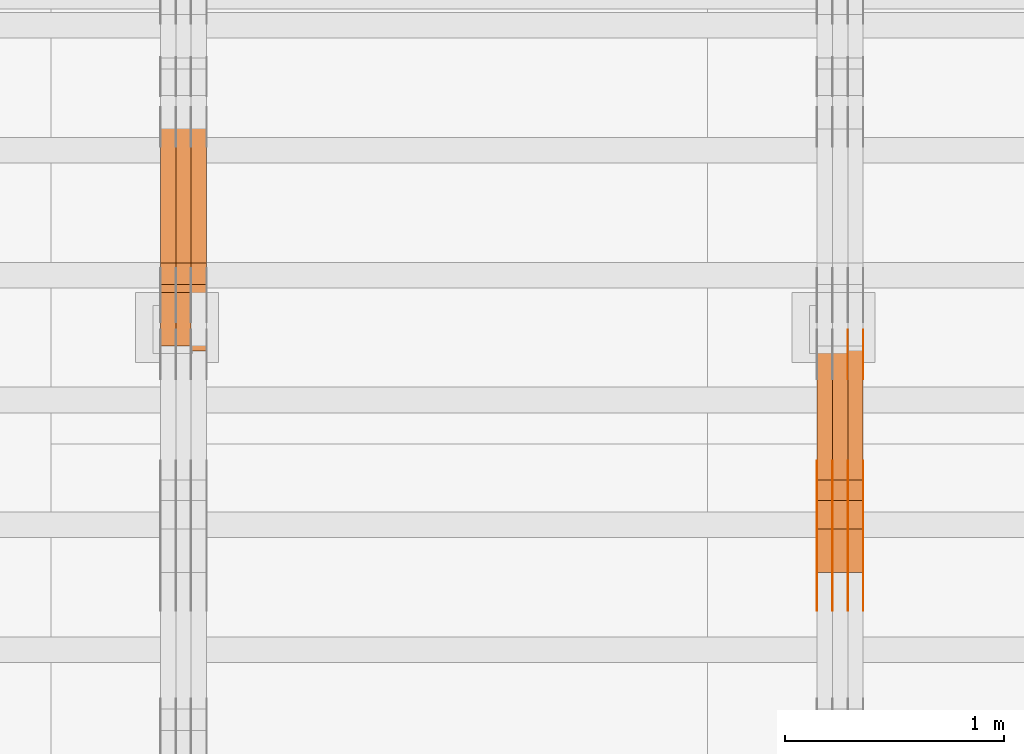
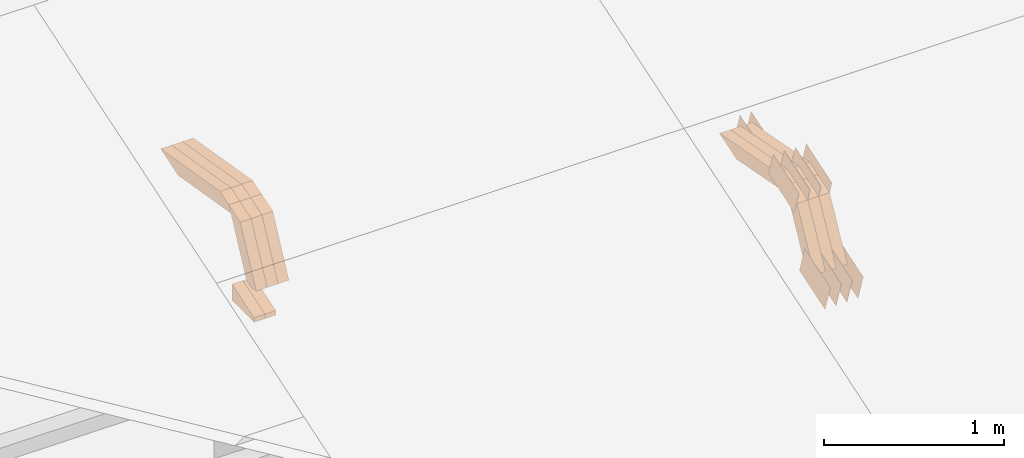
# One storey, part 281 of 385: 28 proxies.
"""IFC2X3 building model written with IfcOpenShell, lengths in millimetres."""

import ifcopenshell
import ifcopenshell.guid

model = None  # the IFC model being written
_history = None  # IfcOwnerHistory: only IFC2X3 demands one
_inside = {}  # id of a spatial element -> (the spatial element, [elements in it])
_under = {}  # id of a project, library or spatial element -> (it, [spatial elements below it])
_declared = {}  # id of a project -> (the project, [libraries it declares])
_typed = {}  # id of a type object -> (the type object, [elements of that type])
_made_of = {}  # id of a material, layer set ... -> (it, [elements and type objects made of it])


def new_model(schema):
    """Start an empty IFC model of exactly this schema.

    Asked for "IFC4X3", IfcOpenShell would pick the latest addendum, in which some entities
    have other attributes; the version numbers below select the first issue.
    IFC2X3 requires an IfcOwnerHistory on every rooted entity: one is made here for all.
    """
    global model, _history
    if schema == "IFC4X3":
        model = ifcopenshell.file(schema_version=(4, 3, 0, 0))
    else:
        model = ifcopenshell.file(schema=schema)
    _inside.clear()
    _under.clear()
    _declared.clear()
    _typed.clear()
    _made_of.clear()
    _history = None
    if model.schema == "IFC2X3":
        org = make("IfcOrganization", Name="unknown")
        user = make(
            "IfcPersonAndOrganization",
            ThePerson=make("IfcPerson", FamilyName="unknown"),
            TheOrganization=org,
        )
        app = make(
            "IfcApplication",
            ApplicationDeveloper=org,
            Version="unknown",
            ApplicationFullName="unknown",
            ApplicationIdentifier="unknown",
        )
        _history = make(
            "IfcOwnerHistory",
            OwningUser=user,
            OwningApplication=app,
            ChangeAction="ADDED",
            CreationDate=0,
        )
    return model


def make(cls, **values):
    """One entity of the class cls with the attributes given. An attribute that is None is left unset."""
    return model.create_entity(
        cls, **{name: value for name, value in values.items() if value is not None}
    )


def entity(cls, *values):
    """Any entity or typed value of the class cls, its attributes in the order of the schema. None: left unset."""
    e = model.create_entity(cls)
    for i, value in enumerate(values):
        if value is not None:
            e[i] = value
    return e


def rooted(cls, **values):
    """An entity with a GlobalId (a new one), such as an element, a storey or a relation."""
    return make(cls, GlobalId=ifcopenshell.guid.new(), OwnerHistory=_history, **values)


def si_unit(unit_type, name, prefix=None):
    """IfcSIUnit, for example si_unit("LENGTHUNIT", "METRE", prefix="MILLI")."""
    return make("IfcSIUnit", UnitType=unit_type, Prefix=prefix, Name=name)


def converted_unit(unit_type, name, factor, base, dimensions=None, offset=None):
    """IfcConversionBasedUnit, such as the inch: factor (a typed value) times the base unit."""
    return make(
        "IfcConversionBasedUnit"
        if offset is None
        else "IfcConversionBasedUnitWithOffset",
        ConversionOffset=offset,
        Dimensions=None
        if dimensions is None
        else entity("IfcDimensionalExponents", *dimensions),
        UnitType=unit_type,
        Name=name,
        ConversionFactor=make(
            "IfcMeasureWithUnit", ValueComponent=factor, UnitComponent=base
        ),
    )


def derived_unit(unit_type, elements):
    """IfcDerivedUnit: a product of units, each with its exponent."""
    return make(
        "IfcDerivedUnit",
        Elements=[
            make("IfcDerivedUnitElement", Unit=unit, Exponent=power)
            for unit, power in elements
        ],
        UnitType=unit_type,
    )


def assignment(units):
    """IfcUnitAssignment: the units of a project."""
    return None if units is None else make("IfcUnitAssignment", Units=units)


def point(xyz):
    """IfcCartesianPoint."""
    return None if xyz is None else make("IfcCartesianPoint", Coordinates=xyz)


def direction(xyz):
    """IfcDirection."""
    return None if xyz is None else make("IfcDirection", DirectionRatios=xyz)


def frame(location, z_axis=None, x_axis=None):
    """IfcAxis2Placement3D, a coordinate frame: its origin and axes. An axis left out is left unset."""
    return make(
        "IfcAxis2Placement3D",
        Location=point(location),
        Axis=direction(z_axis),
        RefDirection=direction(x_axis),
    )


def origin():
    """The frame at (0, 0, 0) with its axes left unset."""
    return frame((0.0, 0.0, 0.0))


def place(relative_to, where):
    """IfcLocalPlacement: puts the frame where relative to a parent placement (None: the world)."""
    return make(
        "IfcLocalPlacement", PlacementRelTo=relative_to, RelativePlacement=where
    )


def context(
    kind, dimensions, precision=None, world=None, true_north=None, identifier=None
):
    """IfcGeometricRepresentationContext, for example the 3D "Model" context."""
    return make(
        "IfcGeometricRepresentationContext",
        ContextIdentifier=identifier,
        ContextType=kind,
        CoordinateSpaceDimension=dimensions,
        Precision=precision,
        WorldCoordinateSystem=world,
        TrueNorth=true_north,
    )


def subcontext(parent, identifier, kind, view, scale=None):
    """IfcGeometricRepresentationSubContext, for example "Body" below "Model"."""
    return make(
        "IfcGeometricRepresentationSubContext",
        ContextIdentifier=identifier,
        ContextType=kind,
        ParentContext=parent,
        TargetScale=scale,
        TargetView=view,
    )


def project(units=None, contexts=None):
    """IfcProject with its units and contexts."""
    return rooted(
        "IfcProject",
        Name="project",
        RepresentationContexts=contexts,
        UnitsInContext=assignment(units),
    )


def spatial(cls, under=None, at=None, **own):
    """A site, building, storey or space (cls), placed at a placement, below another one or the project."""
    s = rooted(cls, ObjectPlacement=at, **own)
    if under is not None:
        _under.setdefault(under.id(), (under, []))[1].append(s)
    return s


def polyline(points):
    """IfcPolyline through the points."""
    return make("IfcPolyline", Points=[point(p) for p in points])


def outline(outer, holes=None, kind="AREA"):
    """IfcArbitraryClosedProfileDef: a profile drawn as a closed curve; with holes, ...WithVoids."""
    if holes is None:
        return make("IfcArbitraryClosedProfileDef", ProfileType=kind, OuterCurve=outer)
    return make(
        "IfcArbitraryProfileDefWithVoids",
        ProfileType=kind,
        OuterCurve=outer,
        InnerCurves=holes,
    )


def extrude(swept, where, along, depth):
    """IfcExtrudedAreaSolid: the profile swept, set in the frame where, extruded along a direction by depth."""
    return make(
        "IfcExtrudedAreaSolid",
        SweptArea=swept,
        Position=where,
        ExtrudedDirection=direction(along),
        Depth=depth,
    )


def shape(context_of_items, identifier, shape_type, items):
    """IfcShapeRepresentation: the items that make up one representation, for example the "Body"."""
    return make(
        "IfcShapeRepresentation",
        ContextOfItems=context_of_items,
        RepresentationIdentifier=identifier,
        RepresentationType=shape_type,
        Items=items,
    )


def source(mapping_origin, context_of_items, identifier, shape_type, items):
    """IfcRepresentationMap: a shape defined once, which mapped items show again and again."""
    return make(
        "IfcRepresentationMap",
        MappingOrigin=mapping_origin,
        MappedRepresentation=shape(context_of_items, identifier, shape_type, items),
    )


def transform(
    local_origin,
    x_axis=None,
    y_axis=None,
    z_axis=None,
    scale=None,
    scale2=None,
    scale3=None,
    uniform=True,
):
    """IfcCartesianTransformationOperator3D, or its non-uniform kind. x_axis, y_axis, z_axis: its Axis1, 2, 3."""
    if uniform:
        return make(
            "IfcCartesianTransformationOperator3D",
            Axis1=direction(x_axis),
            Axis2=direction(y_axis),
            LocalOrigin=point(local_origin),
            Scale=scale,
            Axis3=direction(z_axis),
        )
    return make(
        "IfcCartesianTransformationOperator3DnonUniform",
        Axis1=direction(x_axis),
        Axis2=direction(y_axis),
        LocalOrigin=point(local_origin),
        Scale=scale,
        Axis3=direction(z_axis),
        Scale2=scale2,
        Scale3=scale3,
    )


def mapped(mapping_source, mapping_target):
    """IfcMappedItem: shows the shape of a source again, moved by a transform."""
    return make(
        "IfcMappedItem", MappingSource=mapping_source, MappingTarget=mapping_target
    )


def material(Name=None, Category=None):
    """IfcMaterial."""
    return make("IfcMaterial", Name=Name, Category=Category)


def made_of(thing, what):
    """Note that an element or type object is made of a material, layer set ...; save() writes the relation."""
    if what is not None:
        _made_of.setdefault(what.id(), (what, []))[1].append(thing)
    return thing


def type_object(cls, material=None, **own):
    """A type object (cls), such as IfcWallType, which elements share."""
    return made_of(rooted(cls, **own), material)


def type_shapes(of_type, sources):
    """Give a type object the sources (RepresentationMaps) that its elements show as mapped items."""
    of_type.RepresentationMaps = sources


def element(
    cls,
    number,
    at=None,
    inside=None,
    cuts=None,
    type_object=None,
    material=None,
    context=None,
    identifier="Body",
    shape_type=None,
    held_by="IfcProductDefinitionShape",
    body=None,
    shapes=None,
    **own,
):
    """One element of the class cls, such as IfcWall. Its Tag is "e" and its number.

    at: its placement. inside: the storey or other place that contains it. cuts: it is an
    opening in that element (IfcRelVoidsElement). A single representation is given by context,
    identifier, shape_type and body (its items); several are given by shapes. held_by: the class
    of the entity that holds the representations. save() writes the other relations.
    """
    e = rooted(cls, Tag="e%d" % number, ObjectPlacement=at, **own)
    if body is not None:
        shapes = [shape(context, identifier, shape_type, body)]
    if shapes is not None:
        e.Representation = make(held_by, Representations=shapes)
    if inside is not None:
        _inside.setdefault(inside.id(), (inside, []))[1].append(e)
    if cuts is not None:
        rooted(
            "IfcRelVoidsElement", RelatingBuildingElement=cuts, RelatedOpeningElement=e
        )
    if type_object is not None:
        _typed.setdefault(type_object.id(), (type_object, []))[1].append(e)
    return made_of(e, material)


def aggregate(whole, parts):
    """IfcRelAggregates: a whole, such as a stair, and the parts it consists of."""
    return rooted("IfcRelAggregates", RelatingObject=whole, RelatedObjects=parts)


def save(model, path):
    """Write the relations noted so far, then the file.

    IfcRelAggregates (storeys below a building ...), IfcRelContainedInSpatialStructure (elements
    in a storey), IfcRelDefinesByType, IfcRelAssociatesMaterial and IfcRelDeclares: one each for
    every whole, place, type object, material and project.
    """
    for whole, parts in _under.values():
        aggregate(whole, parts)
    for where, things in _inside.values():
        rooted(
            "IfcRelContainedInSpatialStructure",
            RelatedElements=things,
            RelatingStructure=where,
        )
    for kind, things in _typed.values():
        rooted("IfcRelDefinesByType", RelatedObjects=things, RelatingType=kind)
    for what, things in _made_of.values():
        rooted("IfcRelAssociatesMaterial", RelatedObjects=things, RelatingMaterial=what)
    for by, libraries in _declared.values():
        rooted("IfcRelDeclares", RelatingContext=by, RelatedDefinitions=libraries)
    model.write(path)


model = new_model("IFC2X3")

# Units and contexts
model_context = context("Model", 3, precision=0.01, world=origin(), true_north=direction((6.12303176911189e-17, 1.0)))
body_context = subcontext(model_context, "Body", "Model", "MODEL_VIEW")
ifc_project = project(units=[si_unit("LENGTHUNIT", "METRE", prefix="MILLI"), si_unit("AREAUNIT", "SQUARE_METRE"), si_unit("VOLUMEUNIT", "CUBIC_METRE"), converted_unit("PLANEANGLEUNIT", "DEGREE", entity("IfcRatioMeasure", 0.0174532925199433), si_unit("PLANEANGLEUNIT", "RADIAN"), dimensions=[0, 0, 0, 0, 0, 0, 0]), si_unit("MASSUNIT", "GRAM", prefix="KILO"), derived_unit("MASSDENSITYUNIT", [(si_unit("MASSUNIT", "GRAM", prefix="KILO"), 1), (si_unit("LENGTHUNIT", "METRE"), -3)]), si_unit("TIMEUNIT", "SECOND"), si_unit("FREQUENCYUNIT", "HERTZ"), si_unit("THERMODYNAMICTEMPERATUREUNIT", "DEGREE_CELSIUS"), derived_unit("THERMALTRANSMITTANCEUNIT", [(si_unit("MASSUNIT", "GRAM", prefix="KILO"), 1), (si_unit("THERMODYNAMICTEMPERATUREUNIT", "KELVIN"), -1), (si_unit("TIMEUNIT", "SECOND"), -3)]), derived_unit("VOLUMETRICFLOWRATEUNIT", [(si_unit("LENGTHUNIT", "METRE"), 3), (si_unit("TIMEUNIT", "SECOND"), -1)]), si_unit("ELECTRICCURRENTUNIT", "AMPERE"), si_unit("ELECTRICVOLTAGEUNIT", "VOLT"), si_unit("POWERUNIT", "WATT"), si_unit("FORCEUNIT", "NEWTON", prefix="KILO"), si_unit("ILLUMINANCEUNIT", "LUX"), si_unit("LUMINOUSFLUXUNIT", "LUMEN"), si_unit("LUMINOUSINTENSITYUNIT", "CANDELA"), derived_unit("USERDEFINED", [(si_unit("MASSUNIT", "GRAM", prefix="KILO"), -1), (si_unit("LENGTHUNIT", "METRE"), -2), (si_unit("TIMEUNIT", "SECOND"), 3), (si_unit("LUMINOUSFLUXUNIT", "LUMEN"), 1)]), derived_unit("LINEARVELOCITYUNIT", [(si_unit("LENGTHUNIT", "METRE"), 1), (si_unit("TIMEUNIT", "SECOND"), -1)]), si_unit("PRESSUREUNIT", "PASCAL"), derived_unit("USERDEFINED", [(si_unit("LENGTHUNIT", "METRE"), -2), (si_unit("MASSUNIT", "GRAM", prefix="KILO"), 1), (si_unit("TIMEUNIT", "SECOND"), -2)])], contexts=[model_context])

# Site, building, storey
site_placement = place(None, origin())
site = spatial("IfcSite", under=ifc_project, at=site_placement, CompositionType="ELEMENT")
building_placement = place(site_placement, origin())
building = spatial("IfcBuilding", under=site, at=building_placement, CompositionType="ELEMENT")
storey_placement = place(building_placement, origin())
storey = spatial("IfcBuildingStorey", under=building, at=storey_placement, Name="Default", CompositionType="ELEMENT", Elevation=0.0)

# Proxies
ifc_material_1 = material(Name="IfcSurfaceStyle #483912")
building_element_proxy_type_1 = type_object("IfcBuildingElementProxyType", PredefinedType="NOTDEFINED", material=ifc_material_1)
shared_shape_1 = source(origin(), body_context, "Body", "SweptSolid", [
    extrude(outline(polyline([(-149.99966632326, -95.9999759039407), (149.999881095801, -95.9999759039407), (150.000557367591, 95.9999759039407), (-150.000772140132, 95.9999759039406), (-149.99966632326, -95.9999759039407)])), frame((150.000557367591, 96.0004291135906, 0.0), z_axis=(0.0, 0.0, 1.0), x_axis=(-1.0, 0.0, 0.0)), (0.0, 0.0, 1.0), 1.29999999999999),
])
type_shapes(building_element_proxy_type_1, [shared_shape_1])
proxy_1_placement = place(building_placement, frame((39386.3, 10934.7734375, 2766.8759765625), z_axis=(-1.0, 0.0, 0.0), x_axis=(0.0, 0.951056516295124, 0.309016994375039)))
element("IfcBuildingElementProxy", 1, at=proxy_1_placement, inside=storey, type_object=building_element_proxy_type_1, material=ifc_material_1, context=body_context, shape_type="MappedRepresentation", body=[
    mapped(shared_shape_1, transform((0.0, 0.0, 0.0), scale=1.0)),
])
ifc_material_2 = material(Name="IfcSurfaceStyle #483855")
building_element_proxy_type_2 = type_object("IfcBuildingElementProxyType", PredefinedType="NOTDEFINED", material=ifc_material_2)
shared_shape_2 = source(origin(), body_context, "Body", "SweptSolid", [
    extrude(outline(polyline([(-149.99966632326, -95.9999759039407), (149.999881095801, -95.9999759039407), (150.000557367591, 95.9999759039407), (-150.000772140132, 95.9999759039406), (-149.99966632326, -95.9999759039407)])), frame((150.000557367591, 96.0004291135906, 0.0), z_axis=(0.0, 0.0, 1.0), x_axis=(-1.0, 0.0, 0.0)), (0.0, 0.0, 1.0), 1.29999999999999),
])
type_shapes(building_element_proxy_type_2, [shared_shape_2])
proxy_2_placement = place(building_placement, frame((39315.0, 10934.7734375, 2766.8759765625), z_axis=(-1.0, 0.0, 0.0), x_axis=(0.0, 0.951056516295124, 0.309016994375039)))
element("IfcBuildingElementProxy", 2, at=proxy_2_placement, inside=storey, type_object=building_element_proxy_type_2, material=ifc_material_2, context=body_context, shape_type="MappedRepresentation", body=[
    mapped(shared_shape_2, transform((0.0, 0.0, 0.0), scale=1.0)),
])
ifc_material_3 = material(Name="IfcSurfaceStyle #483798")
building_element_proxy_type_3 = type_object("IfcBuildingElementProxyType", PredefinedType="NOTDEFINED", material=ifc_material_3)
shared_shape_3 = source(origin(), body_context, "Body", "SweptSolid", [
    extrude(outline(polyline([(-149.99966632326, -95.9999759039407), (149.999881095801, -95.9999759039407), (150.000557367591, 95.9999759039407), (-150.000772140132, 95.9999759039406), (-149.99966632326, -95.9999759039407)])), frame((150.000557367591, 96.0004291135906, 0.0), z_axis=(0.0, 0.0, 1.0), x_axis=(-1.0, 0.0, 0.0)), (0.0, 0.0, 1.0), 1.29999999999999),
])
type_shapes(building_element_proxy_type_3, [shared_shape_3])
proxy_3_placement = place(building_placement, frame((39316.3, 10934.7734375, 2766.8759765625), z_axis=(-1.0, 0.0, 0.0), x_axis=(0.0, 0.951056516295124, 0.309016994375039)))
element("IfcBuildingElementProxy", 3, at=proxy_3_placement, inside=storey, type_object=building_element_proxy_type_3, material=ifc_material_3, context=body_context, shape_type="MappedRepresentation", body=[
    mapped(shared_shape_3, transform((0.0, 0.0, 0.0), scale=1.0)),
])
ifc_material_4 = material(Name="IfcSurfaceStyle #483741")
building_element_proxy_type_4 = type_object("IfcBuildingElementProxyType", PredefinedType="NOTDEFINED", material=ifc_material_4)
shared_shape_4 = source(origin(), body_context, "Body", "SweptSolid", [
    extrude(outline(polyline([(-149.99966632326, -95.9999759039407), (149.999881095801, -95.9999759039407), (150.000557367591, 95.9999759039407), (-150.000772140132, 95.9999759039406), (-149.99966632326, -95.9999759039407)])), frame((150.000557367591, 96.0004291135906, 0.0), z_axis=(0.0, 0.0, 1.0), x_axis=(-1.0, 0.0, 0.0)), (0.0, 0.0, 1.0), 1.29999999999998),
])
type_shapes(building_element_proxy_type_4, [shared_shape_4])
proxy_4_placement = place(building_placement, frame((39245.0, 10934.7734375, 2766.8759765625), z_axis=(-1.0, 0.0, 0.0), x_axis=(0.0, 0.951056516295124, 0.309016994375039)))
element("IfcBuildingElementProxy", 4, at=proxy_4_placement, inside=storey, type_object=building_element_proxy_type_4, material=ifc_material_4, context=body_context, shape_type="MappedRepresentation", body=[
    mapped(shared_shape_4, transform((0.0, 0.0, 0.0), scale=1.0)),
])
ifc_material_5 = material(Name="IfcSurfaceStyle #483684")
building_element_proxy_type_5 = type_object("IfcBuildingElementProxyType", PredefinedType="NOTDEFINED", material=ifc_material_5)
shared_shape_5 = source(origin(), body_context, "Body", "SweptSolid", [
    extrude(outline(polyline([(-149.99966632326, -95.9999759039407), (149.999881095801, -95.9999759039407), (150.000557367591, 95.9999759039407), (-150.000772140132, 95.9999759039406), (-149.99966632326, -95.9999759039407)])), frame((150.000557367591, 96.0004291135906, 0.0), z_axis=(0.0, 0.0, 1.0), x_axis=(-1.0, 0.0, 0.0)), (0.0, 0.0, 1.0), 1.29999999999998),
])
type_shapes(building_element_proxy_type_5, [shared_shape_5])
proxy_5_placement = place(building_placement, frame((39246.3, 10934.7734375, 2766.8759765625), z_axis=(-1.0, 0.0, 0.0), x_axis=(0.0, 0.951056516295124, 0.309016994375039)))
element("IfcBuildingElementProxy", 5, at=proxy_5_placement, inside=storey, type_object=building_element_proxy_type_5, material=ifc_material_5, context=body_context, shape_type="MappedRepresentation", body=[
    mapped(shared_shape_5, transform((0.0, 0.0, 0.0), scale=1.0)),
])
ifc_material_6 = material(Name="IfcSurfaceStyle #483627")
building_element_proxy_type_6 = type_object("IfcBuildingElementProxyType", PredefinedType="NOTDEFINED", material=ifc_material_6)
shared_shape_6 = source(origin(), body_context, "Body", "SweptSolid", [
    extrude(outline(polyline([(-149.99966632326, -95.9999759039407), (149.999881095801, -95.9999759039407), (150.000557367591, 95.9999759039407), (-150.000772140132, 95.9999759039406), (-149.99966632326, -95.9999759039407)])), frame((150.000557367591, 96.0004291135906, 0.0), z_axis=(0.0, 0.0, 1.0), x_axis=(-1.0, 0.0, 0.0)), (0.0, 0.0, 1.0), 1.29999999999998),
])
type_shapes(building_element_proxy_type_6, [shared_shape_6])
proxy_6_placement = place(building_placement, frame((39175.0, 10934.7734375, 2766.8759765625), z_axis=(-1.0, 0.0, 0.0), x_axis=(0.0, 0.951056516295124, 0.309016994375039)))
element("IfcBuildingElementProxy", 6, at=proxy_6_placement, inside=storey, type_object=building_element_proxy_type_6, material=ifc_material_6, context=body_context, shape_type="MappedRepresentation", body=[
    mapped(shared_shape_6, transform((0.0, 0.0, 0.0), scale=1.0)),
])
ifc_material_7 = material(Name="IfcSurfaceStyle #482544")
building_element_proxy_type_7 = type_object("IfcBuildingElementProxyType", PredefinedType="NOTDEFINED", material=ifc_material_7)
shared_shape_7 = source(origin(), body_context, "Body", "SweptSolid", [
    extrude(outline(polyline([(-99.9997874178038, -60.0000528641967), (99.9998102700997, -60.0000528641967), (99.9998251396068, 60.0000528641967), (-99.9998479919027, 60.0000528641967), (-99.9997874178038, -60.0000528641967)])), frame((99.9999918898597, 60.0000528641967, 0.0), z_axis=(0.0, 0.0, 1.0), x_axis=(-1.0, 0.0, 0.0)), (0.0, 0.0, 1.0), 1.3),
])
type_shapes(building_element_proxy_type_7, [shared_shape_7])
proxy_7_placement = place(building_placement, frame((39386.3, 11991.9568177725, 3072.52282247925), z_axis=(-1.0, 0.0, 0.0), x_axis=(0.0, 0.951056516295124, 0.309016994375039)))
element("IfcBuildingElementProxy", 7, at=proxy_7_placement, inside=storey, type_object=building_element_proxy_type_7, material=ifc_material_7, context=body_context, shape_type="MappedRepresentation", body=[
    mapped(shared_shape_7, transform((0.0, 0.0, 0.0), scale=1.0)),
])
ifc_material_8 = material(Name="IfcSurfaceStyle #482487")
building_element_proxy_type_8 = type_object("IfcBuildingElementProxyType", PredefinedType="NOTDEFINED", material=ifc_material_8)
shared_shape_8 = source(origin(), body_context, "Body", "SweptSolid", [
    extrude(outline(polyline([(-99.9997874178038, -60.0000528641967), (99.9998102700997, -60.0000528641967), (99.9998251396068, 60.0000528641967), (-99.9998479919027, 60.0000528641967), (-99.9997874178038, -60.0000528641967)])), frame((99.9999918898597, 60.0000528641967, 0.0), z_axis=(0.0, 0.0, 1.0), x_axis=(-1.0, 0.0, 0.0)), (0.0, 0.0, 1.0), 1.3),
])
type_shapes(building_element_proxy_type_8, [shared_shape_8])
proxy_8_placement = place(building_placement, frame((39315.0, 11991.9568177725, 3072.52282247925), z_axis=(-1.0, 0.0, 0.0), x_axis=(0.0, 0.951056516295124, 0.309016994375039)))
element("IfcBuildingElementProxy", 8, at=proxy_8_placement, inside=storey, type_object=building_element_proxy_type_8, material=ifc_material_8, context=body_context, shape_type="MappedRepresentation", body=[
    mapped(shared_shape_8, transform((0.0, 0.0, 0.0), scale=1.0)),
])
ifc_material_9 = material(Name="IfcSurfaceStyle #474336")
building_element_proxy_type_9 = type_object("IfcBuildingElementProxyType", PredefinedType="NOTDEFINED", material=ifc_material_9)
shared_shape_9 = source(origin(), body_context, "Body", "SweptSolid", [
    extrude(outline(polyline([(-150.000273478628, -84.0002987844282), (149.999198496832, -84.0002987844282), (150.000273478627, 84.0002987844282), (-149.999198496831, 84.0002987844282), (-150.000273478628, -84.0002987844282)])), frame((150.000273478627, 84.0002987844282, 0.0), z_axis=(0.0, 0.0, 1.0), x_axis=(-1.0, 0.0, 0.0)), (0.0, 0.0, 1.0), 1.29999999999999),
])
type_shapes(building_element_proxy_type_9, [shared_shape_9])
proxy_9_placement = place(building_placement, frame((39386.3, 11283.0116722926, 3194.09682266857), z_axis=(-1.0, 0.0, 0.0), x_axis=(0.0, 0.951056516295154, 0.309016994374948)))
element("IfcBuildingElementProxy", 9, at=proxy_9_placement, inside=storey, type_object=building_element_proxy_type_9, material=ifc_material_9, context=body_context, shape_type="MappedRepresentation", body=[
    mapped(shared_shape_9, transform((0.0, 0.0, 0.0), scale=1.0)),
])
ifc_material_10 = material(Name="IfcSurfaceStyle #474279")
building_element_proxy_type_10 = type_object("IfcBuildingElementProxyType", PredefinedType="NOTDEFINED", material=ifc_material_10)
shared_shape_10 = source(origin(), body_context, "Body", "SweptSolid", [
    extrude(outline(polyline([(-150.000273478628, -84.0002987844282), (149.999198496832, -84.0002987844282), (150.000273478627, 84.0002987844282), (-149.999198496831, 84.0002987844282), (-150.000273478628, -84.0002987844282)])), frame((150.000273478627, 84.0002987844282, 0.0), z_axis=(0.0, 0.0, 1.0), x_axis=(-1.0, 0.0, 0.0)), (0.0, 0.0, 1.0), 1.29999999999999),
])
type_shapes(building_element_proxy_type_10, [shared_shape_10])
proxy_10_placement = place(building_placement, frame((39315.0, 11283.0116722926, 3194.09682266857), z_axis=(-1.0, 0.0, 0.0), x_axis=(0.0, 0.951056516295154, 0.309016994374948)))
element("IfcBuildingElementProxy", 10, at=proxy_10_placement, inside=storey, type_object=building_element_proxy_type_10, material=ifc_material_10, context=body_context, shape_type="MappedRepresentation", body=[
    mapped(shared_shape_10, transform((0.0, 0.0, 0.0), scale=1.0)),
])
ifc_material_11 = material(Name="IfcSurfaceStyle #474222")
building_element_proxy_type_11 = type_object("IfcBuildingElementProxyType", PredefinedType="NOTDEFINED", material=ifc_material_11)
shared_shape_11 = source(origin(), body_context, "Body", "SweptSolid", [
    extrude(outline(polyline([(-150.000273478628, -84.0002987844282), (149.999198496832, -84.0002987844282), (150.000273478627, 84.0002987844282), (-149.999198496831, 84.0002987844282), (-150.000273478628, -84.0002987844282)])), frame((150.000273478627, 84.0002987844282, 0.0), z_axis=(0.0, 0.0, 1.0), x_axis=(-1.0, 0.0, 0.0)), (0.0, 0.0, 1.0), 1.29999999999999),
])
type_shapes(building_element_proxy_type_11, [shared_shape_11])
proxy_11_placement = place(building_placement, frame((39316.3, 11283.0116722926, 3194.09682266857), z_axis=(-1.0, 0.0, 0.0), x_axis=(0.0, 0.951056516295154, 0.309016994374948)))
element("IfcBuildingElementProxy", 11, at=proxy_11_placement, inside=storey, type_object=building_element_proxy_type_11, material=ifc_material_11, context=body_context, shape_type="MappedRepresentation", body=[
    mapped(shared_shape_11, transform((0.0, 0.0, 0.0), scale=1.0)),
])
ifc_material_12 = material(Name="IfcSurfaceStyle #474165")
building_element_proxy_type_12 = type_object("IfcBuildingElementProxyType", PredefinedType="NOTDEFINED", material=ifc_material_12)
shared_shape_12 = source(origin(), body_context, "Body", "SweptSolid", [
    extrude(outline(polyline([(-150.000273478628, -84.0002987844282), (149.999198496832, -84.0002987844282), (150.000273478627, 84.0002987844282), (-149.999198496831, 84.0002987844282), (-150.000273478628, -84.0002987844282)])), frame((150.000273478627, 84.0002987844282, 0.0), z_axis=(0.0, 0.0, 1.0), x_axis=(-1.0, 0.0, 0.0)), (0.0, 0.0, 1.0), 1.29999999999998),
])
type_shapes(building_element_proxy_type_12, [shared_shape_12])
proxy_12_placement = place(building_placement, frame((39245.0, 11283.0116722926, 3194.09682266857), z_axis=(-1.0, 0.0, 0.0), x_axis=(0.0, 0.951056516295154, 0.309016994374948)))
element("IfcBuildingElementProxy", 12, at=proxy_12_placement, inside=storey, type_object=building_element_proxy_type_12, material=ifc_material_12, context=body_context, shape_type="MappedRepresentation", body=[
    mapped(shared_shape_12, transform((0.0, 0.0, 0.0), scale=1.0)),
])
ifc_material_13 = material(Name="IfcSurfaceStyle #474108")
building_element_proxy_type_13 = type_object("IfcBuildingElementProxyType", PredefinedType="NOTDEFINED", material=ifc_material_13)
shared_shape_13 = source(origin(), body_context, "Body", "SweptSolid", [
    extrude(outline(polyline([(-150.000273478628, -84.0002987844282), (149.999198496832, -84.0002987844282), (150.000273478627, 84.0002987844282), (-149.999198496831, 84.0002987844282), (-150.000273478628, -84.0002987844282)])), frame((150.000273478627, 84.0002987844282, 0.0), z_axis=(0.0, 0.0, 1.0), x_axis=(-1.0, 0.0, 0.0)), (0.0, 0.0, 1.0), 1.29999999999998),
])
type_shapes(building_element_proxy_type_13, [shared_shape_13])
proxy_13_placement = place(building_placement, frame((39246.3, 11283.0116722926, 3194.09682266857), z_axis=(-1.0, 0.0, 0.0), x_axis=(0.0, 0.951056516295154, 0.309016994374948)))
element("IfcBuildingElementProxy", 13, at=proxy_13_placement, inside=storey, type_object=building_element_proxy_type_13, material=ifc_material_13, context=body_context, shape_type="MappedRepresentation", body=[
    mapped(shared_shape_13, transform((0.0, 0.0, 0.0), scale=1.0)),
])
ifc_material_14 = material(Name="IfcSurfaceStyle #474051")
building_element_proxy_type_14 = type_object("IfcBuildingElementProxyType", PredefinedType="NOTDEFINED", material=ifc_material_14)
shared_shape_14 = source(origin(), body_context, "Body", "SweptSolid", [
    extrude(outline(polyline([(-150.000273478628, -84.0002987844282), (149.999198496832, -84.0002987844282), (150.000273478627, 84.0002987844282), (-149.999198496831, 84.0002987844282), (-150.000273478628, -84.0002987844282)])), frame((150.000273478627, 84.0002987844282, 0.0), z_axis=(0.0, 0.0, 1.0), x_axis=(-1.0, 0.0, 0.0)), (0.0, 0.0, 1.0), 1.29999999999998),
])
type_shapes(building_element_proxy_type_14, [shared_shape_14])
proxy_14_placement = place(building_placement, frame((39175.0, 11283.0116722926, 3194.09682266857), z_axis=(-1.0, 0.0, 0.0), x_axis=(0.0, 0.951056516295154, 0.309016994374948)))
element("IfcBuildingElementProxy", 14, at=proxy_14_placement, inside=storey, type_object=building_element_proxy_type_14, material=ifc_material_14, context=body_context, shape_type="MappedRepresentation", body=[
    mapped(shared_shape_14, transform((0.0, 0.0, 0.0), scale=1.0)),
])
ifc_material_15 = material(Name="IfcSurfaceStyle #464040")
building_element_proxy_type_15 = type_object("IfcBuildingElementProxyType", Name="T1-W9 464038", PredefinedType="NOTDEFINED", material=ifc_material_15)
shared_shape_15 = source(origin(), body_context, "Body", "SweptSolid", [
    extrude(outline(polyline([(-287.457507623288, -47.5000268597988), (288.590479960635, -47.5000268597988), (273.55062971372, -2.33146189358546e-05), (186.625054999886, 47.5000385171083), (-461.308657050953, 47.5000385171083), (-287.457507623288, -47.5000268597988)])), frame((288.590945855618, 47.5000968036551, 0.0), z_axis=(0.0, 0.0, 1.0), x_axis=(-1.0, 0.0, 0.0)), (0.0, 0.0, 1.0), 70.0),
])
type_shapes(building_element_proxy_type_15, [shared_shape_15])
proxy_15_placement = place(building_placement, frame((39385.0, 11432.1200855376, 3205.63308612017), z_axis=(-1.0, 0.0, 0.0), x_axis=(0.0, 0.982760503514031, -0.184883186722992)))
element("IfcBuildingElementProxy", 15, at=proxy_15_placement, inside=storey, type_object=building_element_proxy_type_15, material=ifc_material_15, Name="T1-W9", context=body_context, shape_type="MappedRepresentation", body=[
    mapped(shared_shape_15, transform((0.0, 0.0, 0.0), scale=1.0)),
])
ifc_material_16 = material(Name="IfcSurfaceStyle #463974")
building_element_proxy_type_16 = type_object("IfcBuildingElementProxyType", Name="T1-W9 463972", PredefinedType="NOTDEFINED", material=ifc_material_16)
shared_shape_16 = source(origin(), body_context, "Body", "SweptSolid", [
    extrude(outline(polyline([(-287.457507623288, -47.5000268597988), (288.590479960635, -47.5000268597988), (273.55062971372, -2.33146189358546e-05), (186.625054999886, 47.5000385171083), (-461.308657050953, 47.5000385171083), (-287.457507623288, -47.5000268597988)])), frame((288.590945855618, 47.5000968036551, 0.0), z_axis=(0.0, 0.0, 1.0), x_axis=(-1.0, 0.0, 0.0)), (0.0, 0.0, 1.0), 70.0),
])
type_shapes(building_element_proxy_type_16, [shared_shape_16])
proxy_16_placement = place(building_placement, frame((39315.0, 11432.1200855376, 3205.63308612017), z_axis=(-1.0, 0.0, 0.0), x_axis=(0.0, 0.982760503514031, -0.184883186722992)))
element("IfcBuildingElementProxy", 16, at=proxy_16_placement, inside=storey, type_object=building_element_proxy_type_16, material=ifc_material_16, Name="T1-W9", context=body_context, shape_type="MappedRepresentation", body=[
    mapped(shared_shape_16, transform((0.0, 0.0, 0.0), scale=1.0)),
])
ifc_material_17 = material(Name="IfcSurfaceStyle #463908")
building_element_proxy_type_17 = type_object("IfcBuildingElementProxyType", Name="T1-W9 463906", PredefinedType="NOTDEFINED", material=ifc_material_17)
shared_shape_17 = source(origin(), body_context, "Body", "SweptSolid", [
    extrude(outline(polyline([(-287.457507623288, -47.5000268597988), (288.590479960635, -47.5000268597988), (273.55062971372, -2.33146189358546e-05), (186.625054999886, 47.5000385171083), (-461.308657050953, 47.5000385171083), (-287.457507623288, -47.5000268597988)])), frame((288.590945855618, 47.5000968036551, 0.0), z_axis=(0.0, 0.0, 1.0), x_axis=(-1.0, 0.0, 0.0)), (0.0, 0.0, 1.0), 70.0),
])
type_shapes(building_element_proxy_type_17, [shared_shape_17])
proxy_17_placement = place(building_placement, frame((39245.0, 11432.1200855376, 3205.63308612017), z_axis=(-1.0, 0.0, 0.0), x_axis=(0.0, 0.982760503514031, -0.184883186722992)))
element("IfcBuildingElementProxy", 17, at=proxy_17_placement, inside=storey, type_object=building_element_proxy_type_17, material=ifc_material_17, Name="T1-W9", context=body_context, shape_type="MappedRepresentation", body=[
    mapped(shared_shape_17, transform((0.0, 0.0, 0.0), scale=1.0)),
])
ifc_material_18 = material(Name="IfcSurfaceStyle #463644")
building_element_proxy_type_18 = type_object("IfcBuildingElementProxyType", Name="T1-W32 463642", PredefinedType="NOTDEFINED", material=ifc_material_18)
shared_shape_18 = source(origin(), body_context, "Body", "SweptSolid", [
    extrude(outline(polyline([(-312.414547135921, -47.5000544873059), (136.677011757652, -47.5000544873059), (186.250996577889, 0.000369497452627243), (202.753116295831, 47.4998697385796), (-213.26657749545, 47.4998697385796), (-312.414547135921, -47.5000544873059)])), frame((202.753376481939, 47.5001296985553, 0.0), z_axis=(0.0, 0.0, 1.0), x_axis=(-1.0, 0.0, 0.0)), (0.0, 0.0, 1.0), 70.0),
])
type_shapes(building_element_proxy_type_18, [shared_shape_18])
proxy_18_placement = place(building_placement, frame((39385.0, 11110.7808979007, 2747.18129017315), z_axis=(-1.0, 0.0, 0.0), x_axis=(0.0, 0.472919689385906, 0.881105537033526)))
element("IfcBuildingElementProxy", 18, at=proxy_18_placement, inside=storey, type_object=building_element_proxy_type_18, material=ifc_material_18, Name="T1-W32", context=body_context, shape_type="MappedRepresentation", body=[
    mapped(shared_shape_18, transform((0.0, 0.0, 0.0), scale=1.0)),
])
ifc_material_19 = material(Name="IfcSurfaceStyle #463578")
building_element_proxy_type_19 = type_object("IfcBuildingElementProxyType", Name="T1-W32 463576", PredefinedType="NOTDEFINED", material=ifc_material_19)
shared_shape_19 = source(origin(), body_context, "Body", "SweptSolid", [
    extrude(outline(polyline([(-312.414547135921, -47.5000544873059), (136.677011757652, -47.5000544873059), (186.250996577889, 0.000369497452627243), (202.753116295831, 47.4998697385796), (-213.26657749545, 47.4998697385796), (-312.414547135921, -47.5000544873059)])), frame((202.753376481939, 47.5001296985553, 0.0), z_axis=(0.0, 0.0, 1.0), x_axis=(-1.0, 0.0, 0.0)), (0.0, 0.0, 1.0), 70.0),
])
type_shapes(building_element_proxy_type_19, [shared_shape_19])
proxy_19_placement = place(building_placement, frame((39315.0, 11110.7808979007, 2747.18129017315), z_axis=(-1.0, 0.0, 0.0), x_axis=(0.0, 0.472919689385906, 0.881105537033526)))
element("IfcBuildingElementProxy", 19, at=proxy_19_placement, inside=storey, type_object=building_element_proxy_type_19, material=ifc_material_19, Name="T1-W32", context=body_context, shape_type="MappedRepresentation", body=[
    mapped(shared_shape_19, transform((0.0, 0.0, 0.0), scale=1.0)),
])
ifc_material_20 = material(Name="IfcSurfaceStyle #463512")
building_element_proxy_type_20 = type_object("IfcBuildingElementProxyType", Name="T1-W32 463510", PredefinedType="NOTDEFINED", material=ifc_material_20)
shared_shape_20 = source(origin(), body_context, "Body", "SweptSolid", [
    extrude(outline(polyline([(-312.414547135921, -47.5000544873059), (136.677011757652, -47.5000544873059), (186.250996577889, 0.000369497452627243), (202.753116295831, 47.4998697385796), (-213.26657749545, 47.4998697385796), (-312.414547135921, -47.5000544873059)])), frame((202.753376481939, 47.5001296985553, 0.0), z_axis=(0.0, 0.0, 1.0), x_axis=(-1.0, 0.0, 0.0)), (0.0, 0.0, 1.0), 70.0),
])
type_shapes(building_element_proxy_type_20, [shared_shape_20])
proxy_20_placement = place(building_placement, frame((39245.0, 11110.7808979007, 2747.18129017315), z_axis=(-1.0, 0.0, 0.0), x_axis=(0.0, 0.472919689385906, 0.881105537033526)))
element("IfcBuildingElementProxy", 20, at=proxy_20_placement, inside=storey, type_object=building_element_proxy_type_20, material=ifc_material_20, Name="T1-W32", context=body_context, shape_type="MappedRepresentation", body=[
    mapped(shared_shape_20, transform((0.0, 0.0, 0.0), scale=1.0)),
])
ifc_material_21 = material(Name="IfcSurfaceStyle #432071")
building_element_proxy_type_21 = type_object("IfcBuildingElementProxyType", Name="T1-E1 432069", PredefinedType="NOTDEFINED", material=ifc_material_21)
shared_shape_21 = source(origin(), body_context, "Body", "SweptSolid", [
    extrude(outline(polyline([(-75.1378173828004, -122.500000000005), (35.3350830078246, -122.500000000005), (35.3350830078004, 122.500000000005), (4.46765136717545, 122.500000000005), (-75.1378173828004, -122.500000000005)])), frame((35.3350830078246, 122.500000104877, 0.0), z_axis=(0.0, 0.0, 1.0), x_axis=(-1.0, 0.0, 0.0)), (0.0, 0.0, 1.0), 70.0),
])
type_shapes(building_element_proxy_type_21, [shared_shape_21])
proxy_21_placement = place(building_placement, frame((36315.0, 12145.0, 2849.54565429685), z_axis=(-1.0, 0.0, 0.0), x_axis=(0.0, 0.0, 1.0)))
element("IfcBuildingElementProxy", 21, at=proxy_21_placement, inside=storey, type_object=building_element_proxy_type_21, material=ifc_material_21, Name="T1-E1", context=body_context, shape_type="MappedRepresentation", body=[
    mapped(shared_shape_21, transform((0.0, 0.0, 0.0), scale=1.0)),
])
ifc_material_22 = material(Name="IfcSurfaceStyle #432014")
building_element_proxy_type_22 = type_object("IfcBuildingElementProxyType", Name="T1-E1 432012", PredefinedType="NOTDEFINED", material=ifc_material_22)
shared_shape_22 = source(origin(), body_context, "Body", "SweptSolid", [
    extrude(outline(polyline([(-75.1378173828004, -122.500000000005), (35.3350830078246, -122.500000000005), (35.3350830078004, 122.500000000005), (4.46765136717545, 122.500000000005), (-75.1378173828004, -122.500000000005)])), frame((35.3350830078246, 122.500000104877, 0.0), z_axis=(0.0, 0.0, 1.0), x_axis=(-1.0, 0.0, 0.0)), (0.0, 0.0, 1.0), 70.0),
])
type_shapes(building_element_proxy_type_22, [shared_shape_22])
proxy_22_placement = place(building_placement, frame((36245.0, 12145.0, 2849.54565429685), z_axis=(-1.0, 0.0, 0.0), x_axis=(0.0, 0.0, 1.0)))
element("IfcBuildingElementProxy", 22, at=proxy_22_placement, inside=storey, type_object=building_element_proxy_type_22, material=ifc_material_22, Name="T1-E1", context=body_context, shape_type="MappedRepresentation", body=[
    mapped(shared_shape_22, transform((0.0, 0.0, 0.0), scale=1.0)),
])
ifc_material_23 = material(Name="IfcSurfaceStyle #430400")
building_element_proxy_type_23 = type_object("IfcBuildingElementProxyType", Name="T1-W7 430398", PredefinedType="NOTDEFINED", material=ifc_material_23)
shared_shape_23 = source(origin(), body_context, "Body", "SweptSolid", [
    extrude(outline(polyline([(-296.174043820986, -47.5000676566704), (297.841254477443, -47.5000676566704), (283.518570346415, -7.10254316533821e-06), (192.674144473719, 47.500071207942), (-477.859925476591, 47.500071207942), (-296.174043820986, -47.5000676566704)])), frame((297.841254477443, 47.5000816097442, 0.0), z_axis=(0.0, 0.0, 1.0), x_axis=(-1.0, 0.0, 0.0)), (0.0, 0.0, 1.0), 70.0),
])
type_shapes(building_element_proxy_type_23, [shared_shape_23])
proxy_23_placement = place(building_placement, frame((36385.0, 12419.2991208897, 3526.2136755972), z_axis=(-1.0, 0.0, 0.0), x_axis=(0.0, 0.985983815111804, -0.166840991178939)))
element("IfcBuildingElementProxy", 23, at=proxy_23_placement, inside=storey, type_object=building_element_proxy_type_23, material=ifc_material_23, Name="T1-W7", context=body_context, shape_type="MappedRepresentation", body=[
    mapped(shared_shape_23, transform((0.0, 0.0, 0.0), scale=1.0)),
])
ifc_material_24 = material(Name="IfcSurfaceStyle #430334")
building_element_proxy_type_24 = type_object("IfcBuildingElementProxyType", Name="T1-W7 430332", PredefinedType="NOTDEFINED", material=ifc_material_24)
shared_shape_24 = source(origin(), body_context, "Body", "SweptSolid", [
    extrude(outline(polyline([(-296.174043820986, -47.5000676566704), (297.841254477443, -47.5000676566704), (283.518570346415, -7.10254316533821e-06), (192.674144473719, 47.500071207942), (-477.859925476591, 47.500071207942), (-296.174043820986, -47.5000676566704)])), frame((297.841254477443, 47.5000816097442, 0.0), z_axis=(0.0, 0.0, 1.0), x_axis=(-1.0, 0.0, 0.0)), (0.0, 0.0, 1.0), 70.0),
])
type_shapes(building_element_proxy_type_24, [shared_shape_24])
proxy_24_placement = place(building_placement, frame((36315.0, 12419.2991208897, 3526.2136755972), z_axis=(-1.0, 0.0, 0.0), x_axis=(0.0, 0.985983815111804, -0.166840991178939)))
element("IfcBuildingElementProxy", 24, at=proxy_24_placement, inside=storey, type_object=building_element_proxy_type_24, material=ifc_material_24, Name="T1-W7", context=body_context, shape_type="MappedRepresentation", body=[
    mapped(shared_shape_24, transform((0.0, 0.0, 0.0), scale=1.0)),
])
ifc_material_25 = material(Name="IfcSurfaceStyle #430268")
building_element_proxy_type_25 = type_object("IfcBuildingElementProxyType", Name="T1-W7 430266", PredefinedType="NOTDEFINED", material=ifc_material_25)
shared_shape_25 = source(origin(), body_context, "Body", "SweptSolid", [
    extrude(outline(polyline([(-296.174043820986, -47.5000676566704), (297.841254477443, -47.5000676566704), (283.518570346415, -7.10254316533821e-06), (192.674144473719, 47.500071207942), (-477.859925476591, 47.500071207942), (-296.174043820986, -47.5000676566704)])), frame((297.841254477443, 47.5000816097442, 0.0), z_axis=(0.0, 0.0, 1.0), x_axis=(-1.0, 0.0, 0.0)), (0.0, 0.0, 1.0), 70.0),
])
type_shapes(building_element_proxy_type_25, [shared_shape_25])
proxy_25_placement = place(building_placement, frame((36245.0, 12419.2991208897, 3526.2136755972), z_axis=(-1.0, 0.0, 0.0), x_axis=(0.0, 0.985983815111804, -0.166840991178939)))
element("IfcBuildingElementProxy", 25, at=proxy_25_placement, inside=storey, type_object=building_element_proxy_type_25, material=ifc_material_25, Name="T1-W7", context=body_context, shape_type="MappedRepresentation", body=[
    mapped(shared_shape_25, transform((0.0, 0.0, 0.0), scale=1.0)),
])
ifc_material_26 = material(Name="IfcSurfaceStyle #430004")
building_element_proxy_type_26 = type_object("IfcBuildingElementProxyType", Name="T1-W36 430002", PredefinedType="NOTDEFINED", material=ifc_material_26)
shared_shape_26 = source(origin(), body_context, "Body", "SweptSolid", [
    extrude(outline(polyline([(-300.714670922549, -47.4998881108849), (134.031527004269, -47.499888110885), (180.52054953879, -0.000136170977331764), (193.89900152221, 47.500563476126), (-207.736407142719, 47.4993489166213), (-300.714670922549, -47.4998881108849)])), frame((193.899145164686, 47.5001861375837, 0.0), z_axis=(0.0, 0.0, 1.0), x_axis=(-1.0, 3.02403492980632e-06, 0.0)), (0.0, 0.0, 1.0), 70.0),
])
type_shapes(building_element_proxy_type_26, [shared_shape_26])
proxy_26_placement = place(building_placement, frame((36385.0, 12120.5935627532, 3076.1128858536), z_axis=(-1.0, 0.0, 0.0), x_axis=(0.0, 0.444384650266842, 0.895836080210669)))
element("IfcBuildingElementProxy", 26, at=proxy_26_placement, inside=storey, type_object=building_element_proxy_type_26, material=ifc_material_26, Name="T1-W36", context=body_context, shape_type="MappedRepresentation", body=[
    mapped(shared_shape_26, transform((0.0, 0.0, 0.0), scale=1.0)),
])
ifc_material_27 = material(Name="IfcSurfaceStyle #429938")
building_element_proxy_type_27 = type_object("IfcBuildingElementProxyType", Name="T1-W36 429936", PredefinedType="NOTDEFINED", material=ifc_material_27)
shared_shape_27 = source(origin(), body_context, "Body", "SweptSolid", [
    extrude(outline(polyline([(-300.714670922549, -47.4998881108849), (134.031527004269, -47.499888110885), (180.52054953879, -0.000136170977331764), (193.89900152221, 47.500563476126), (-207.736407142719, 47.4993489166213), (-300.714670922549, -47.4998881108849)])), frame((193.899145164686, 47.5001861375837, 0.0), z_axis=(0.0, 0.0, 1.0), x_axis=(-1.0, 3.02403492980632e-06, 0.0)), (0.0, 0.0, 1.0), 70.0),
])
type_shapes(building_element_proxy_type_27, [shared_shape_27])
proxy_27_placement = place(building_placement, frame((36315.0, 12120.5935627532, 3076.1128858536), z_axis=(-1.0, 0.0, 0.0), x_axis=(0.0, 0.444384650266842, 0.895836080210669)))
element("IfcBuildingElementProxy", 27, at=proxy_27_placement, inside=storey, type_object=building_element_proxy_type_27, material=ifc_material_27, Name="T1-W36", context=body_context, shape_type="MappedRepresentation", body=[
    mapped(shared_shape_27, transform((0.0, 0.0, 0.0), scale=1.0)),
])
ifc_material_28 = material(Name="IfcSurfaceStyle #429872")
building_element_proxy_type_28 = type_object("IfcBuildingElementProxyType", Name="T1-W36 429870", PredefinedType="NOTDEFINED", material=ifc_material_28)
shared_shape_28 = source(origin(), body_context, "Body", "SweptSolid", [
    extrude(outline(polyline([(-300.714670922549, -47.4998881108849), (134.031527004269, -47.499888110885), (180.52054953879, -0.000136170977331764), (193.89900152221, 47.500563476126), (-207.736407142719, 47.4993489166213), (-300.714670922549, -47.4998881108849)])), frame((193.899145164686, 47.5001861375837, 0.0), z_axis=(0.0, 0.0, 1.0), x_axis=(-1.0, 3.02403492980632e-06, 0.0)), (0.0, 0.0, 1.0), 70.0),
])
type_shapes(building_element_proxy_type_28, [shared_shape_28])
proxy_28_placement = place(building_placement, frame((36245.0, 12120.5935627532, 3076.1128858536), z_axis=(-1.0, 0.0, 0.0), x_axis=(0.0, 0.444384650266842, 0.895836080210669)))
element("IfcBuildingElementProxy", 28, at=proxy_28_placement, inside=storey, type_object=building_element_proxy_type_28, material=ifc_material_28, Name="T1-W36", context=body_context, shape_type="MappedRepresentation", body=[
    mapped(shared_shape_28, transform((0.0, 0.0, 0.0), scale=1.0)),
])

save(model, "model.ifc")
